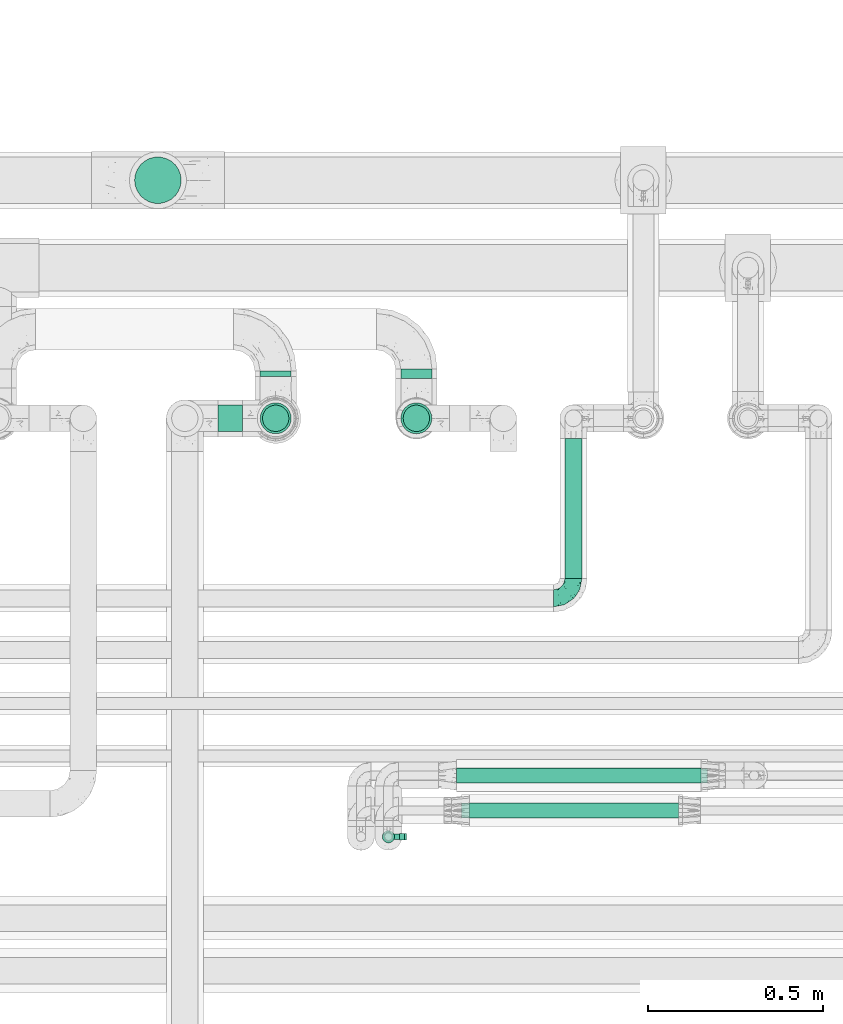
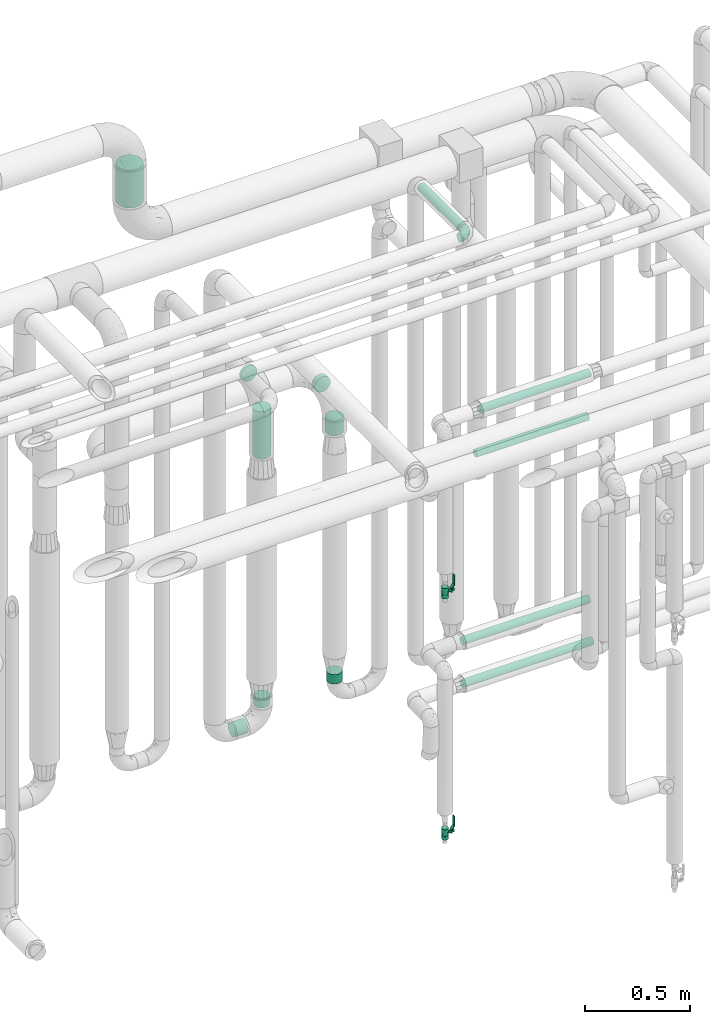
# One storey, part 707 of 824: 13 flow segments, 2 flow controllers, 1 flow fitting.
"""IFC2X3 building model written with IfcOpenShell, lengths in millimetres."""

from ifc_helpers import new_model, entity, si_unit, converted_unit, derived_unit, direction, frame, origin, origin_2d_with_axis, place, context, subcontext, project, spatial, polyline, circle, outline, extrude, faceted_brep, source, transform, mapped, material, material_list, type_object, type_shapes, element, save


model = new_model("IFC2X3")

# Units and contexts
model_context = context("Model", 3, precision=0.01, world=origin(), true_north=direction((6.12303176911189e-17, 1.0)))
body_context = subcontext(model_context, "Body", "Model", "MODEL_VIEW")
ifc_project = project(units=[si_unit("LENGTHUNIT", "METRE", prefix="MILLI"), si_unit("AREAUNIT", "SQUARE_METRE"), si_unit("VOLUMEUNIT", "CUBIC_METRE"), converted_unit("PLANEANGLEUNIT", "DEGREE", entity("IfcRatioMeasure", 0.0174532925199433), si_unit("PLANEANGLEUNIT", "RADIAN"), dimensions=[0, 0, 0, 0, 0, 0, 0]), si_unit("MASSUNIT", "GRAM", prefix="KILO"), derived_unit("MASSDENSITYUNIT", [(si_unit("MASSUNIT", "GRAM", prefix="KILO"), 1), (si_unit("LENGTHUNIT", "METRE"), -3)]), derived_unit("MOMENTOFINERTIAUNIT", [(si_unit("LENGTHUNIT", "METRE"), 4)]), si_unit("TIMEUNIT", "SECOND"), si_unit("FREQUENCYUNIT", "HERTZ"), si_unit("THERMODYNAMICTEMPERATUREUNIT", "DEGREE_CELSIUS"), derived_unit("THERMALTRANSMITTANCEUNIT", [(si_unit("MASSUNIT", "GRAM", prefix="KILO"), 1), (si_unit("THERMODYNAMICTEMPERATUREUNIT", "KELVIN"), -1), (si_unit("TIMEUNIT", "SECOND"), -3)]), derived_unit("VOLUMETRICFLOWRATEUNIT", [(si_unit("LENGTHUNIT", "METRE"), 3), (si_unit("TIMEUNIT", "SECOND"), -1)]), derived_unit("MASSFLOWRATEUNIT", [(si_unit("MASSUNIT", "GRAM", prefix="KILO"), 1), (si_unit("TIMEUNIT", "SECOND"), -1)]), derived_unit("ROTATIONALFREQUENCYUNIT", [(si_unit("TIMEUNIT", "SECOND"), -1)]), si_unit("ELECTRICCURRENTUNIT", "AMPERE"), si_unit("ELECTRICVOLTAGEUNIT", "VOLT"), si_unit("POWERUNIT", "WATT"), si_unit("FORCEUNIT", "NEWTON", prefix="KILO"), si_unit("ILLUMINANCEUNIT", "LUX"), si_unit("LUMINOUSFLUXUNIT", "LUMEN"), si_unit("LUMINOUSINTENSITYUNIT", "CANDELA"), derived_unit("USERDEFINED", [(si_unit("MASSUNIT", "GRAM", prefix="KILO"), -1), (si_unit("LENGTHUNIT", "METRE"), -2), (si_unit("TIMEUNIT", "SECOND"), 3), (si_unit("LUMINOUSFLUXUNIT", "LUMEN"), 1)]), derived_unit("LINEARVELOCITYUNIT", [(si_unit("LENGTHUNIT", "METRE"), 1), (si_unit("TIMEUNIT", "SECOND"), -1)]), si_unit("PRESSUREUNIT", "PASCAL"), derived_unit("USERDEFINED", [(si_unit("LENGTHUNIT", "METRE"), -2), (si_unit("MASSUNIT", "GRAM", prefix="KILO"), 1), (si_unit("TIMEUNIT", "SECOND"), -2)]), derived_unit("LINEARFORCEUNIT", [(si_unit("MASSUNIT", "GRAM", prefix="KILO"), 1), (si_unit("LENGTHUNIT", "METRE"), 1), (si_unit("TIMEUNIT", "SECOND"), -2), (si_unit("LENGTHUNIT", "METRE"), -1)]), derived_unit("PLANARFORCEUNIT", [(si_unit("MASSUNIT", "GRAM", prefix="KILO"), 1), (si_unit("LENGTHUNIT", "METRE"), 1), (si_unit("TIMEUNIT", "SECOND"), -2), (si_unit("LENGTHUNIT", "METRE"), -2)])], contexts=[model_context])

# Site, building, storey
site_placement = place(None, origin())
site = spatial("IfcSite", under=ifc_project, at=site_placement, CompositionType="ELEMENT")
building_placement = place(site_placement, origin())
building = spatial("IfcBuilding", under=site, at=building_placement, CompositionType="ELEMENT")
storey_placement = place(building_placement, frame((0.0, 0.0, 28200.0)))
storey = spatial("IfcBuildingStorey", under=building, at=storey_placement, CompositionType="ELEMENT", Elevation=28200.0)

# Flow segments
pipe_segment_type_1 = type_object("IfcPipeSegmentType", PredefinedType="NOTDEFINED")
flow_segment_1_placement = place(storey_placement, frame((57842.95, 18112.0, 3090.0)))
element("IfcFlowSegment", 1, at=flow_segment_1_placement, inside=storey, type_object=pipe_segment_type_1, context=body_context, shape_type="SweptSolid", body=[
    extrude(circle(Radius=66.5, at=origin_2d_with_axis()), frame((68.1, 68.1, 0.0), z_axis=(0.0, 0.0, 1.0), x_axis=(-1.0, 0.0, 0.0)), (0.0, 0.0, 1.0), 219.743188805708),
])
pipe_segment_type_2 = type_object("IfcPipeSegmentType", PredefinedType="NOTDEFINED")
flow_segment_2_placement = place(storey_placement, frame((58201.72, 17620.0, 2254.15)))
element("IfcFlowSegment", 2, at=flow_segment_2_placement, inside=storey, type_object=pipe_segment_type_2, context=body_context, shape_type="SweptSolid", body=[
    extrude(circle(Radius=44.25, at=origin_2d_with_axis()), frame((45.85, 0.0, 45.85), z_axis=(0.0, 1.0, 0.0), x_axis=(-1.0, 0.0, 0.0)), (0.0, 0.0, 1.0), 15.0961141089939),
])
flow_segment_3_placement = place(storey_placement, frame((58201.72, 17454.15, 1902.45)))
element("IfcFlowSegment", 3, at=flow_segment_3_placement, inside=storey, type_object=pipe_segment_type_2, context=body_context, shape_type="SweptSolid", body=[
    extrude(circle(Radius=44.25, at=origin_2d_with_axis()), frame((45.85, 45.85, 0.0)), (0.0, 0.0, 1.0), 277.547222472813),
])
flow_segment_4_placement = place(storey_placement, frame((58082.89, 17460.65, 310.65)))
element("IfcFlowSegment", 4, at=flow_segment_4_placement, inside=storey, type_object=pipe_segment_type_2, context=body_context, shape_type="SweptSolid", body=[
    extrude(circle(Radius=37.75, at=origin_2d_with_axis()), frame((0.0, 39.35, 39.35), z_axis=(1.0, 0.0, 0.0), x_axis=(0.0, -1.0, 0.0)), (0.0, 0.0, 1.0), 69.6845769329227),
])
for number, where in (
    (5, (58208.22, 17460.65, 445.0)),
    (6, (58610.04, 17460.65, 445.0)),
):
    element("IfcFlowSegment", number, at=place(storey_placement, frame(where)), inside=storey, type_object=pipe_segment_type_2, context=body_context, shape_type="SweptSolid", body=[
        extrude(circle(Radius=37.75, at=origin_2d_with_axis()), frame((39.35, 39.35, 0.0), z_axis=(0.0, 0.0, 1.0), x_axis=(-1.0, 0.0, 0.0)), (0.0, 0.0, 1.0), 55.0000000000005),
    ])
flow_segment_5_placement = place(storey_placement, frame((59072.54, 17042.69, 3174.4)))
element("IfcFlowSegment", 7, at=flow_segment_5_placement, inside=storey, type_object=pipe_segment_type_2, context=body_context, shape_type="SweptSolid", body=[
    extrude(circle(Radius=24.0, at=origin_2d_with_axis()), frame((25.6, 0.0, 25.6), z_axis=(0.0, 1.0, 0.0), x_axis=(-1.0, 0.0, 0.0)), (0.0, 0.0, 1.0), 400.304686356029),
])
flow_segment_6_placement = place(storey_placement, frame((58603.54, 17614.0, 2054.15)))
element("IfcFlowSegment", 8, at=flow_segment_6_placement, inside=storey, type_object=pipe_segment_type_2, context=body_context, shape_type="SweptSolid", body=[
    extrude(circle(Radius=44.25, at=origin_2d_with_axis()), frame((45.85, 0.0, 45.85), z_axis=(0.0, 1.0, 0.0), x_axis=(-1.0, 0.0, 0.0)), (0.0, 0.0, 1.0), 27.0961141089868),
])
flow_segment_7_placement = place(storey_placement, frame((58603.54, 17454.15, 1898.17)))
element("IfcFlowSegment", 9, at=flow_segment_7_placement, inside=storey, type_object=pipe_segment_type_2, context=body_context, shape_type="SweptSolid", body=[
    extrude(circle(Radius=44.25, at=origin_2d_with_axis()), frame((45.85, 45.85, 0.0)), (0.0, 0.0, 1.0), 87.8307333425285),
])
flow_segment_8_placement = place(storey_placement, frame((58764.02, 16456.48, 977.25)))
element("IfcFlowSegment", 10, at=flow_segment_8_placement, inside=storey, type_object=pipe_segment_type_2, context=body_context, shape_type="SweptSolid", body=[
    extrude(circle(Radius=21.15, at=origin_2d_with_axis()), frame((0.0, 22.75, 22.75), z_axis=(1.0, 0.0, 6.7602214637812e-06), x_axis=(0.0, 1.0, 0.0)), (0.0, 0.0, 1.0), 717.619049674226),
])
flow_segment_9_placement = place(storey_placement, frame((58764.02, 16456.91, 1227.25)))
element("IfcFlowSegment", 11, at=flow_segment_9_placement, inside=storey, type_object=pipe_segment_type_2, context=body_context, shape_type="SweptSolid", body=[
    extrude(circle(Radius=21.15, at=origin_2d_with_axis()), frame((0.0, 22.75, 22.75), z_axis=(1.0, 0.0, 0.0), x_axis=(0.0, -1.0, 0.0)), (0.0, 0.0, 1.0), 698.842962557812),
])
flow_segment_10_placement = place(storey_placement, frame((58778.82, 16357.09, 2377.25)))
element("IfcFlowSegment", 12, at=flow_segment_10_placement, inside=storey, type_object=pipe_segment_type_2, context=body_context, shape_type="SweptSolid", body=[
    extrude(circle(Radius=21.15, at=origin_2d_with_axis()), frame((0.0, 22.75, 22.75), z_axis=(1.0, 0.0, 0.0), x_axis=(0.0, 1.0, 0.0)), (0.0, 0.0, 1.0), 620.000000000006),
])
flow_segment_11_placement = place(storey_placement, frame((58801.1, 16357.09, 2627.25)))
element("IfcFlowSegment", 13, at=flow_segment_11_placement, inside=storey, type_object=pipe_segment_type_2, context=body_context, shape_type="SweptSolid", body=[
    extrude(circle(Radius=21.15, at=origin_2d_with_axis()), frame((0.0, 22.75, 22.75), z_axis=(1.0, 0.0, 0.0), x_axis=(0.0, -1.0, 0.0)), (0.0, 0.0, 1.0), 608.330451835312),
])

# Flow controllers
ifc_material = material()
ifc_material_list = material_list([ifc_material, ifc_material, ifc_material, ifc_material, ifc_material])
valve_type = type_object("IfcValveType", PredefinedType="NOTDEFINED", material=ifc_material_list)
shared_shape_1 = source(origin(), body_context, "Body", "SweptSolid", [
    extrude(circle(Radius=17.5, at=origin_2d_with_axis()), frame((-30.5, 0.0, 0.0), z_axis=(1.0, 0.0, 0.0), x_axis=(0.0, 1.0, 0.0)), (0.0, 0.0, 1.0), 20.3333333333333),
    extrude(circle(Radius=16.0, at=origin_2d_with_axis()), frame((-10.17, 0.0, 0.0), z_axis=(1.0, 0.0, 0.0), x_axis=(0.0, 1.0, 0.0)), (0.0, 0.0, 1.0), 20.3333333333333),
    extrude(circle(Radius=17.5, at=origin_2d_with_axis()), frame((10.17, 0.0, 0.0), z_axis=(1.0, 0.0, 0.0), x_axis=(0.0, 1.0, 0.0)), (0.0, 0.0, 1.0), 20.3333333333333),
    extrude(outline(polyline([(-38.75, -5.0), (-38.75, -10.0), (-17.92, -10.0), (2.08, 5.0), (56.25, 5.0), (56.25, 10.0), (0.42, 10.0), (-19.58, -5.0), (-38.75, -5.0)])), frame((28.75, -8.75, 41.5), z_axis=(0.0, -1.0, 0.0), x_axis=(1.0, 0.0, 0.0)), (0.0, 0.0, -1.0), 17.5),
    extrude(circle(Radius=8.0, at=origin_2d_with_axis()), origin(), (0.0, 0.0, 1.0), 49.0),
])
type_shapes(valve_type, [shared_shape_1])
for number, where, z_axis, x_axis in (
    (14, (58569.59, 16304.84, 1710.2), (1.0, 0.0, 0.0), (0.0, 0.0, 1.0)),
    (15, (58569.59, 16304.85, 302.5), (1.0, 0.0, 0.0), (0.0, 0.0, 1.0)),
):
    element("IfcFlowController", number, at=place(storey_placement, frame(where, z_axis=z_axis, x_axis=x_axis)), inside=storey, type_object=valve_type, material=ifc_material, context=body_context, shape_type="MappedRepresentation", body=[
        mapped(shared_shape_1, transform((0.0, 0.0, 0.0), scale=1.0)),
    ])

# Flow fitting
pipe_fitting_type = type_object("IfcPipeFittingType", PredefinedType="NOTDEFINED", material=ifc_material)
shared_shape_2 = source(origin(), body_context, "Body", "Brep", [
    faceted_brep([(-57.0, 12.07, -20.91), (-57.0, 6.25, -23.33), (-57.0, 0.0, -24.15), (-57.0, -6.25, -23.33), (-57.0, -12.08, -20.91), (-57.0, -17.08, -17.08), (-57.0, -20.91, -12.08), (-57.0, -23.33, -6.25), (-57.0, -24.15, 0.0), (-57.0, -23.33, 6.25), (-57.0, -20.91, 12.07), (-57.0, -17.08, 17.08), (-57.0, -12.08, 20.91), (-57.0, -6.25, 23.33), (-57.0, 0.0, 24.15), (-57.0, 6.25, 23.33), (-57.0, 12.07, 20.91), (-57.0, 17.08, 17.08), (-57.0, 20.91, 12.07), (-57.0, 23.33, 6.25), (-57.0, 24.15, 0.0), (-57.0, 23.33, -6.25), (-57.0, 20.91, -12.08), (-57.0, 17.08, -17.08), (0.0, 57.0, -24.15), (-6.25, 57.0, -23.33), (-12.07, 57.0, -20.91), (-17.08, 57.0, -17.08), (-20.91, 57.0, -12.08), (-23.33, 57.0, -6.25), (-24.15, 57.0, 0.0), (-23.33, 57.0, 6.25), (-20.91, 57.0, 12.07), (-17.08, 57.0, 17.08), (-12.07, 57.0, 20.91), (-6.25, 57.0, 23.33), (0.0, 57.0, 24.15), (6.25, 57.0, 23.33), (12.08, 57.0, 20.91), (17.08, 57.0, 17.08), (20.91, 57.0, 12.07), (23.33, 57.0, 6.25), (24.15, 57.0, 0.0), (23.33, 57.0, -6.25), (20.91, 57.0, -12.08), (17.08, 57.0, -17.08), (12.08, 57.0, -20.91), (6.25, 57.0, -23.33), (14.9, 21.14, 6.17), (13.61, 24.64, 12.48), (6.23, 8.95, 8.98), (-41.47, -21.06, 0.0), (-41.92, -18.38, 13.72), (-24.64, -13.61, 12.48), (-37.37, -13.24, 18.15), (-6.8, -4.93, 8.18), (-21.76, -15.19, 6.22), (-12.78, -9.18, 0.0), (-37.73, -20.51, 7.75), (-7.38, 7.38, 20.24), (-23.37, -4.26, 20.42), (-11.9, -3.19, 15.86), (-42.14, -8.7, 21.82), (13.24, 37.37, 18.15), (9.33, 23.53, 16.85), (4.26, 23.37, 20.42), (2.77, 10.92, 15.55), (-29.46, 0.91, 23.52), (-44.13, 20.56, 15.69), (-39.25, 26.33, 10.88), (-49.02, 22.92, 9.96), (-34.58, 23.87, 17.15), (-15.8, 6.8, 22.81), (-8.67, 20.47, 23.88), (-18.12, 12.9, 24.08), (-48.29, 14.92, 19.65), (-44.06, -2.85, 23.78), (-9.23, 48.95, 22.58), (-3.78, 42.74, 24.07), (-40.34, 4.26, 24.09), (-44.02, 26.14, 5.46), (-44.04, 9.88, 22.74), (-4.95, 16.87, 22.52), (-2.75, 1.43, 12.5), (-25.48, 40.98, 10.71), (20.51, 37.73, 7.75), (18.38, 41.92, 13.72), (8.7, 42.14, 21.82), (-25.95, -17.97, 0.0), (2.85, 44.06, 23.78), (21.06, 41.47, 0.0), (17.97, 25.95, 0.0), (-24.04, -9.27, 17.13), (-33.26, 33.26, 5.86), (-28.55, 40.57, 0.0), (-40.57, 28.55, 0.0), (-25.29, 47.19, 4.06), (-27.01, 31.1, 16.77), (-15.7, 43.95, 19.9), (-20.27, 45.22, 15.61), (-30.53, 31.98, 12.64), (-11.28, 38.33, 22.92), (-9.97, 27.88, 24.09), (-20.15, 30.26, 21.25), (-31.25, 11.75, 23.64), (-28.75, 7.23, 24.15), (-29.53, 18.06, 22.27), (-28.44, 24.21, 20.02), (-37.55, 17.7, 20.26), (-15.88, 29.25, 22.99), (-20.82, 20.82, 23.44), (-0.91, 29.46, 23.52), (-13.5, -7.67, 12.04), (1.49, 1.56, 5.16), (8.86, 10.35, 4.59), (0.38, -0.38, 0.0), (9.18, 12.78, 0.0), (-37.37, -13.24, -18.15), (8.86, 10.35, -4.59), (-45.22, 20.27, -15.61), (-43.95, 15.7, -19.9), (-38.33, 11.28, -22.92), (-48.95, 9.23, -22.58), (-47.19, 25.29, -4.06), (-33.26, 33.26, -5.86), (18.38, 41.92, -13.72), (-30.26, 20.15, -21.25), (2.85, 44.06, -23.78), (-4.26, 40.34, -24.09), (-40.98, 25.48, -10.71), (-41.92, -18.38, -13.72), (9.25, 23.5, -16.92), (4.26, 23.37, -20.42), (13.24, 37.37, -18.15), (-37.73, -20.51, -7.75), (-11.75, 31.25, -23.64), (-7.23, 28.75, -24.15), (-12.9, 18.12, -24.08), (8.7, 42.14, -21.82), (-44.06, -2.85, -23.78), (-6.8, 15.8, -22.81), (-20.47, 8.67, -23.88), (-24.64, -13.61, -12.48), (-42.74, 3.78, -24.07), (-18.06, 29.53, -22.27), (-24.21, 28.44, -20.02), (-27.88, 9.97, -24.09), (-31.1, 27.01, -16.77), (-26.14, 44.02, -5.46), (14.9, 21.14, -6.17), (20.51, 37.73, -7.75), (-9.88, 44.04, -22.74), (-20.56, 44.13, -15.69), (-21.76, -15.19, -6.22), (-13.5, -7.67, -12.04), (-24.14, -9.76, -16.74), (-11.9, -3.19, -15.86), (-14.92, 48.29, -19.65), (-23.37, -4.26, -20.42), (-0.91, 29.46, -23.52), (-26.33, 39.25, -10.88), (-23.87, 34.58, -17.15), (-42.14, -8.7, -21.82), (-22.92, 49.02, -9.96), (13.61, 24.64, -12.48), (-31.98, 30.53, -12.64), (-16.87, 4.95, -22.52), (-17.7, 37.55, -20.26), (-29.25, 15.88, -22.99), (-20.82, 20.82, -23.44), (-29.46, 0.91, -23.52), (-7.38, 7.38, -20.24), (2.77, 10.92, -15.55), (6.23, 8.95, -8.98), (-6.8, -4.93, -8.18), (-2.81, 1.41, -12.54), (1.49, 1.56, -5.16)], [[[0, 1, 2, 3, 4, 5, 6, 7, 8, 9, 10, 11, 12, 13, 14, 15, 16, 17, 18, 19, 20, 21, 22, 23]], [[24, 25, 26, 27, 28, 29, 30, 31, 32, 33, 34, 35, 36, 37, 38, 39, 40, 41, 42, 43, 44, 45, 46, 47]], [[48, 49, 50]], [[9, 8, 51]], [[52, 53, 54]], [[55, 56, 57]], [[10, 58, 52]], [[9, 58, 10]], [[59, 60, 61]], [[54, 12, 11]], [[54, 62, 12]], [[63, 39, 38]], [[64, 65, 66]], [[62, 60, 67]], [[68, 69, 70]], [[71, 69, 68]], [[72, 73, 74]], [[16, 75, 17]], [[13, 76, 14]], [[35, 77, 78]], [[14, 79, 15]], [[17, 68, 18]], [[14, 76, 79]], [[20, 19, 80]], [[70, 19, 18]], [[81, 15, 79]], [[15, 81, 16]], [[73, 72, 82]], [[66, 83, 50]], [[32, 31, 84]], [[85, 86, 49]], [[63, 87, 65]], [[56, 58, 88]], [[36, 89, 37]], [[85, 41, 40]], [[36, 35, 78]], [[90, 41, 85]], [[40, 39, 86]], [[12, 62, 13]], [[86, 85, 40]], [[48, 85, 49]], [[85, 91, 90]], [[87, 38, 37]], [[92, 60, 54]], [[80, 69, 93]], [[93, 94, 95]], [[10, 52, 11]], [[94, 96, 30]], [[97, 98, 99]], [[80, 93, 95]], [[100, 97, 84]], [[99, 98, 33]], [[101, 102, 78]], [[103, 101, 98]], [[96, 31, 30]], [[77, 98, 101]], [[77, 35, 34]], [[34, 33, 98]], [[9, 51, 58]], [[87, 63, 38]], [[104, 105, 74]], [[106, 103, 107]], [[106, 81, 104]], [[75, 68, 17]], [[108, 107, 71]], [[33, 32, 99]], [[109, 103, 110]], [[101, 109, 102]], [[89, 78, 111]], [[53, 52, 58]], [[54, 11, 52]], [[60, 62, 54]], [[88, 58, 51]], [[76, 62, 67]], [[53, 112, 92]], [[60, 59, 72]], [[39, 63, 86]], [[49, 86, 63]], [[89, 87, 37]], [[42, 41, 90]], [[111, 82, 65]], [[111, 65, 87]], [[65, 59, 66]], [[104, 81, 79]], [[75, 81, 108]], [[32, 84, 99]], [[97, 99, 84]], [[98, 97, 103]], [[106, 107, 108]], [[74, 102, 110]], [[111, 78, 102]], [[74, 110, 104]], [[74, 67, 72]], [[61, 92, 112]], [[66, 59, 61]], [[56, 53, 58]], [[66, 50, 49]], [[61, 112, 83]], [[66, 49, 64]], [[78, 89, 36]], [[87, 89, 111]], [[62, 76, 13]], [[79, 76, 67]], [[100, 93, 69]], [[96, 93, 84]], [[55, 113, 50]], [[113, 114, 50]], [[104, 79, 105]], [[106, 104, 110]], [[20, 80, 95]], [[85, 48, 91]], [[115, 114, 113]], [[116, 91, 48]], [[70, 80, 19]], [[93, 96, 94]], [[84, 31, 96]], [[103, 106, 110]], [[81, 106, 108]], [[103, 97, 107]], [[71, 107, 97]], [[71, 97, 100]], [[108, 71, 68]], [[79, 67, 105]], [[67, 74, 105]], [[115, 113, 57]], [[112, 56, 55]], [[56, 88, 57]], [[60, 72, 67]], [[82, 72, 59]], [[65, 82, 59]], [[82, 111, 73]], [[111, 102, 73]], [[102, 74, 73]], [[81, 75, 16]], [[68, 75, 108]], [[68, 70, 18]], [[80, 70, 69]], [[98, 77, 34]], [[78, 77, 101]], [[93, 100, 84]], [[71, 100, 69]], [[102, 109, 110]], [[101, 103, 109]], [[53, 92, 54]], [[61, 60, 92]], [[56, 112, 53]], [[83, 112, 55]], [[50, 83, 55]], [[61, 83, 66]], [[49, 63, 64]], [[65, 64, 63]], [[57, 113, 55]], [[114, 115, 116]], [[116, 48, 114]], [[48, 50, 114]], [[117, 5, 4]], [[116, 115, 118]], [[119, 120, 23]], [[121, 122, 120]], [[95, 123, 20]], [[0, 23, 120]], [[124, 95, 94]], [[125, 45, 44]], [[121, 120, 126]], [[24, 127, 128]], [[22, 21, 129]], [[0, 122, 1]], [[5, 117, 130]], [[131, 132, 133]], [[134, 88, 51]], [[135, 136, 137]], [[6, 5, 130]], [[46, 138, 47]], [[139, 3, 2]], [[140, 141, 137]], [[6, 134, 7]], [[134, 130, 142]], [[143, 2, 1]], [[144, 126, 145]], [[121, 146, 143]], [[147, 120, 119]], [[94, 148, 124]], [[149, 150, 91]], [[30, 29, 148]], [[151, 25, 128]], [[27, 152, 28]], [[134, 153, 88]], [[154, 155, 156]], [[27, 26, 157]], [[151, 26, 25]], [[155, 158, 156]], [[24, 47, 127]], [[1, 122, 143]], [[138, 132, 159]], [[160, 152, 161]], [[24, 128, 25]], [[46, 133, 138]], [[162, 117, 4]], [[148, 160, 124]], [[152, 160, 163]], [[154, 142, 155]], [[45, 125, 133]], [[133, 46, 45]], [[125, 164, 133]], [[51, 7, 134]], [[42, 90, 43]], [[165, 147, 129]], [[153, 134, 142]], [[43, 150, 44]], [[162, 4, 3]], [[141, 140, 166]], [[117, 162, 158]], [[163, 29, 28]], [[43, 90, 150]], [[123, 21, 20]], [[144, 151, 135]], [[157, 152, 27]], [[167, 145, 161]], [[23, 22, 119]], [[168, 126, 169]], [[121, 168, 146]], [[139, 143, 170]], [[142, 130, 117]], [[8, 7, 51]], [[134, 6, 130]], [[139, 162, 3]], [[170, 166, 158]], [[170, 158, 162]], [[158, 171, 156]], [[44, 150, 125]], [[91, 150, 90]], [[164, 125, 150]], [[132, 138, 133]], [[127, 138, 159]], [[131, 164, 172]], [[132, 171, 140]], [[135, 151, 128]], [[157, 151, 167]], [[22, 129, 119]], [[147, 119, 129]], [[120, 147, 126]], [[144, 145, 167]], [[137, 146, 169]], [[170, 143, 146]], [[137, 169, 135]], [[137, 159, 140]], [[171, 172, 156]], [[173, 174, 175]], [[156, 175, 154]], [[174, 57, 153]], [[132, 172, 171]], [[172, 164, 173]], [[143, 139, 2]], [[162, 139, 170]], [[138, 127, 47]], [[128, 127, 159]], [[165, 124, 160]], [[123, 124, 129]], [[149, 173, 164]], [[176, 174, 173]], [[135, 128, 136]], [[144, 135, 169]], [[150, 149, 164]], [[176, 118, 115]], [[149, 91, 116]], [[30, 148, 94]], [[163, 148, 29]], [[124, 123, 95]], [[129, 21, 123]], [[126, 144, 169]], [[151, 144, 167]], [[126, 147, 145]], [[161, 145, 147]], [[161, 147, 165]], [[167, 161, 152]], [[128, 159, 136]], [[159, 137, 136]], [[154, 153, 142]], [[132, 140, 159]], [[174, 176, 57]], [[57, 88, 153]], [[166, 140, 171]], [[158, 166, 171]], [[166, 170, 141]], [[170, 146, 141]], [[146, 137, 141]], [[151, 157, 26]], [[152, 157, 167]], [[152, 163, 28]], [[148, 163, 160]], [[120, 122, 0]], [[143, 122, 121]], [[124, 165, 129]], [[161, 165, 160]], [[146, 168, 169]], [[121, 126, 168]], [[142, 117, 155]], [[158, 155, 117]], [[175, 156, 172]], [[153, 154, 174]], [[173, 175, 172]], [[174, 154, 175]], [[164, 131, 133]], [[172, 132, 131]], [[176, 173, 118]], [[57, 176, 115]], [[173, 149, 118]], [[149, 116, 118]]]),
])
type_shapes(pipe_fitting_type, [shared_shape_2])
flow_fitting_placement = place(storey_placement, frame((59098.13, 16985.69, 3200.0)))
element("IfcFlowFitting", 16, at=flow_fitting_placement, inside=storey, type_object=pipe_fitting_type, material=ifc_material, context=body_context, shape_type="MappedRepresentation", body=[
    mapped(shared_shape_2, transform((0.0, 0.0, 0.0), scale=1.0)),
])

save(model, "model.ifc")
